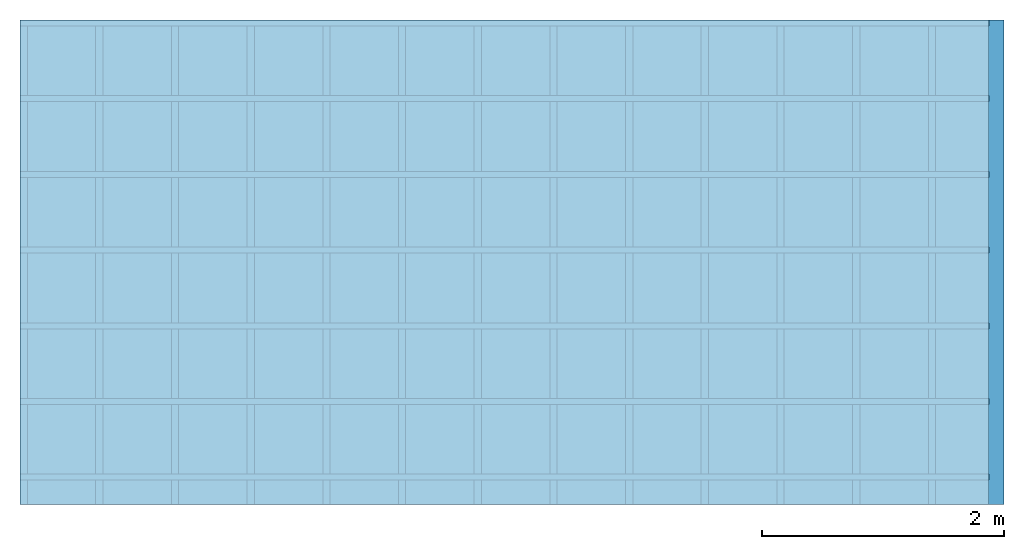
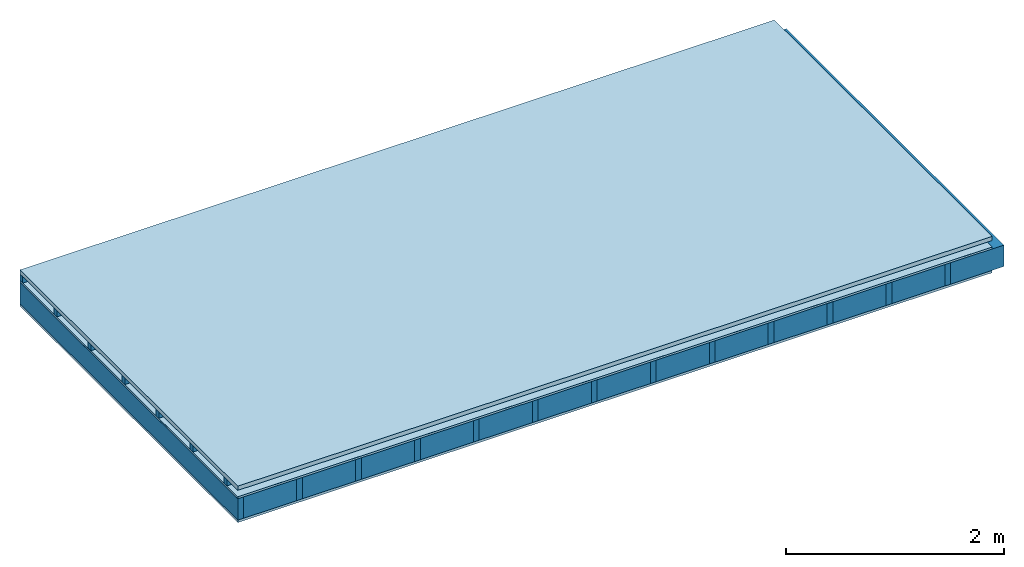
# One storey: 4 plates, 3 members, 1 element without a shape of its own.
"""IFC4 building model written with IfcOpenShell, lengths in metres."""

from ifc_helpers import new_model, si_unit, derived_unit, direction, frame, frame_2d, origin, origin_with_axes, place, context, project, spatial, rectangle, extrude, material, layer, layer_set, type_object, element, aggregate, save


model = new_model("IFC4")

# Units and contexts
plan_context = context("Plan", 3, precision=1e-05, world=origin(), true_north=direction((0.0, 1.0)))
model_context = context("Model", 3, precision=1e-05, world=origin(), true_north=direction((0.0, 1.0)))
ifc_project = project(units=[si_unit("LENGTHUNIT", "METRE"), derived_unit("SOUNDPRESSUREUNIT", [(si_unit("PRESSUREUNIT", "PASCAL", prefix="MICRO"), 0)]), si_unit("ENERGYUNIT", "JOULE", prefix="MEGA"), si_unit("MASSUNIT", "GRAM", prefix="KILO"), derived_unit("THERMALTRANSMITTANCEUNIT", [(si_unit("POWERUNIT", "WATT"), 1), (si_unit("AREAUNIT", "SQUARE_METRE"), -1), (si_unit("THERMODYNAMICTEMPERATUREUNIT", "KELVIN"), -1)]), derived_unit("AREADENSITYUNIT", [(si_unit("MASSUNIT", "GRAM", prefix="KILO"), 1), (si_unit("AREAUNIT", "SQUARE_METRE"), -1)]), derived_unit("USERDEFINED", [(si_unit("ENERGYUNIT", "JOULE", prefix="MEGA"), 1), (si_unit("AREAUNIT", "SQUARE_METRE"), -1)])], contexts=[plan_context, model_context])

# Site, building, storey
site = spatial("IfcSite", under=ifc_project)
building_placement = place(None, origin())
building = spatial("IfcBuilding", under=site, at=building_placement)
storey_placement = place(building_placement, origin())
storey = spatial("IfcBuildingStorey", under=building, at=storey_placement)

# Slab, members, plates
ifc_material_1 = material(Name="Roof tiles", Category="03.015")
ifc_layer_1 = layer(ifc_material_1, 0.047, Name="Roofing")
ifc_layer_2 = layer(None, 0.072, Name="Battens / profiles")
ifc_material_2 = material(Name="Roofing underlay", Category="09.008")
ifc_layer_3 = layer(ifc_material_2, 0.00018, Name="Under the roof")
ifc_material_3 = material(Category="10.009")
ifc_layer_4 = layer(ifc_material_3, 0.022, Name="Exterior insulation layer 1")
ifc_material_4 = material(Name="no composite action")
ifc_layer_5 = layer(ifc_material_4, 0.0, Name="Bond")
ifc_layer_6 = layer(None, 0.24, Name="Supporting structure")
ifc_material_5 = material(Name="of the art")
ifc_layer_7 = layer(ifc_material_5, 0.0, Name="Bond")
ifc_material_6 = material(Category="07.001")
ifc_layer_8 = layer(ifc_material_6, 0.027, Name="Lower layer 1")
ifc_layer_set = layer_set([ifc_layer_1, ifc_layer_2, ifc_layer_3, ifc_layer_4, ifc_layer_5, ifc_layer_6, ifc_layer_7, ifc_layer_8])
slab_type = type_object("IfcSlabType", Name="E0066", PredefinedType="NOTDEFINED", material=ifc_layer_set)
slab_placement = place(None, frame((0.0, 0.0, 0.0), z_axis=(0.0, 0.0, -1.0), x_axis=(1.0, 0.0, 0.0)))
slab = element("IfcSlab", 1, at=slab_placement, inside=storey, type_object=slab_type, material=ifc_layer_set, Name="Slab #1")
ifc_material_7 = material()
member_1_placement = place(slab_placement, origin())
member_1 = element("IfcMember", 2, at=member_1_placement, material=ifc_material_7, Name="Battens / profiles", context=plan_context, shape_type="SweptSolid", body=[
    extrude(rectangle(XDim=0.05, YDim=0.072, at=frame_2d((0.025, 0.036), x_axis=(1.0, 0.0))), frame((0.0, 0.0, 0.047), z_axis=(1.0, 0.0, 0.0), x_axis=(0.0, 1.0, 0.0)), (0.0, 0.0, 1.0), 8.0),
    extrude(rectangle(XDim=0.05, YDim=0.072, at=frame_2d((0.025, 0.036), x_axis=(1.0, 0.0))), frame((0.0, 0.625, 0.047), z_axis=(1.0, 0.0, 0.0), x_axis=(0.0, 1.0, 0.0)), (0.0, 0.0, 1.0), 8.0),
    extrude(rectangle(XDim=0.05, YDim=0.072, at=frame_2d((0.025, 0.036), x_axis=(1.0, 0.0))), frame((0.0, 1.25, 0.047), z_axis=(1.0, 0.0, 0.0), x_axis=(0.0, 1.0, 0.0)), (0.0, 0.0, 1.0), 8.0),
    extrude(rectangle(XDim=0.05, YDim=0.072, at=frame_2d((0.025, 0.036), x_axis=(1.0, 0.0))), frame((0.0, 1.875, 0.047), z_axis=(1.0, 0.0, 0.0), x_axis=(0.0, 1.0, 0.0)), (0.0, 0.0, 1.0), 8.0),
    extrude(rectangle(XDim=0.05, YDim=0.072, at=frame_2d((0.025, 0.036), x_axis=(1.0, 0.0))), frame((0.0, 2.5, 0.047), z_axis=(1.0, 0.0, 0.0), x_axis=(0.0, 1.0, 0.0)), (0.0, 0.0, 1.0), 8.0),
    extrude(rectangle(XDim=0.05, YDim=0.072, at=frame_2d((0.025, 0.036), x_axis=(1.0, 0.0))), frame((0.0, 3.125, 0.047), z_axis=(1.0, 0.0, 0.0), x_axis=(0.0, 1.0, 0.0)), (0.0, 0.0, 1.0), 8.0),
    extrude(rectangle(XDim=0.05, YDim=0.072, at=frame_2d((0.025, 0.036), x_axis=(1.0, 0.0))), frame((0.0, 3.75, 0.047), z_axis=(1.0, 0.0, 0.0), x_axis=(0.0, 1.0, 0.0)), (0.0, 0.0, 1.0), 8.0),
])
ifc_material_8 = material()
member_2_placement = place(slab_placement, origin())
member_2 = element("IfcMember", 3, at=member_2_placement, material=ifc_material_8, Name="Supporting structure", context=plan_context, shape_type="SweptSolid", body=[
    extrude(rectangle(XDim=0.06, YDim=0.24, at=frame_2d((0.03, 0.12), x_axis=(1.0, 0.0))), frame((0.0, 4.0, 0.14118), z_axis=(0.0, -1.0, 0.0), x_axis=(1.0, 0.0, 0.0)), (0.0, 0.0, 1.0), 4.0),
    extrude(rectangle(XDim=0.06, YDim=0.24, at=frame_2d((0.03, 0.12), x_axis=(1.0, 0.0))), frame((0.625, 4.0, 0.14118), z_axis=(0.0, -1.0, 0.0), x_axis=(1.0, 0.0, 0.0)), (0.0, 0.0, 1.0), 4.0),
    extrude(rectangle(XDim=0.06, YDim=0.24, at=frame_2d((0.03, 0.12), x_axis=(1.0, 0.0))), frame((1.25, 4.0, 0.14118), z_axis=(0.0, -1.0, 0.0), x_axis=(1.0, 0.0, 0.0)), (0.0, 0.0, 1.0), 4.0),
    extrude(rectangle(XDim=0.06, YDim=0.24, at=frame_2d((0.03, 0.12), x_axis=(1.0, 0.0))), frame((1.875, 4.0, 0.14118), z_axis=(0.0, -1.0, 0.0), x_axis=(1.0, 0.0, 0.0)), (0.0, 0.0, 1.0), 4.0),
    extrude(rectangle(XDim=0.06, YDim=0.24, at=frame_2d((0.03, 0.12), x_axis=(1.0, 0.0))), frame((2.5, 4.0, 0.14118), z_axis=(0.0, -1.0, 0.0), x_axis=(1.0, 0.0, 0.0)), (0.0, 0.0, 1.0), 4.0),
    extrude(rectangle(XDim=0.06, YDim=0.24, at=frame_2d((0.03, 0.12), x_axis=(1.0, 0.0))), frame((3.125, 4.0, 0.14118), z_axis=(0.0, -1.0, 0.0), x_axis=(1.0, 0.0, 0.0)), (0.0, 0.0, 1.0), 4.0),
    extrude(rectangle(XDim=0.06, YDim=0.24, at=frame_2d((0.03, 0.12), x_axis=(1.0, 0.0))), frame((3.75, 4.0, 0.14118), z_axis=(0.0, -1.0, 0.0), x_axis=(1.0, 0.0, 0.0)), (0.0, 0.0, 1.0), 4.0),
    extrude(rectangle(XDim=0.06, YDim=0.24, at=frame_2d((0.03, 0.12), x_axis=(1.0, 0.0))), frame((4.375, 4.0, 0.14118), z_axis=(0.0, -1.0, 0.0), x_axis=(1.0, 0.0, 0.0)), (0.0, 0.0, 1.0), 4.0),
    extrude(rectangle(XDim=0.06, YDim=0.24, at=frame_2d((0.03, 0.12), x_axis=(1.0, 0.0))), frame((5.0, 4.0, 0.14118), z_axis=(0.0, -1.0, 0.0), x_axis=(1.0, 0.0, 0.0)), (0.0, 0.0, 1.0), 4.0),
    extrude(rectangle(XDim=0.06, YDim=0.24, at=frame_2d((0.03, 0.12), x_axis=(1.0, 0.0))), frame((5.625, 4.0, 0.14118), z_axis=(0.0, -1.0, 0.0), x_axis=(1.0, 0.0, 0.0)), (0.0, 0.0, 1.0), 4.0),
    extrude(rectangle(XDim=0.06, YDim=0.24, at=frame_2d((0.03, 0.12), x_axis=(1.0, 0.0))), frame((6.25, 4.0, 0.14118), z_axis=(0.0, -1.0, 0.0), x_axis=(1.0, 0.0, 0.0)), (0.0, 0.0, 1.0), 4.0),
    extrude(rectangle(XDim=0.06, YDim=0.24, at=frame_2d((0.03, 0.12), x_axis=(1.0, 0.0))), frame((6.875, 4.0, 0.14118), z_axis=(0.0, -1.0, 0.0), x_axis=(1.0, 0.0, 0.0)), (0.0, 0.0, 1.0), 4.0),
    extrude(rectangle(XDim=0.06, YDim=0.24, at=frame_2d((0.03, 0.12), x_axis=(1.0, 0.0))), frame((7.5, 4.0, 0.14118), z_axis=(0.0, -1.0, 0.0), x_axis=(1.0, 0.0, 0.0)), (0.0, 0.0, 1.0), 4.0),
])
ifc_material_9 = material()
member_3_placement = place(slab_placement, origin())
member_3 = element("IfcMember", 4, at=member_3_placement, material=ifc_material_9, Name="Cavity", context=plan_context, shape_type="SweptSolid", body=[
    extrude(rectangle(XDim=0.565, YDim=0.24, at=frame_2d((0.2825, 0.12), x_axis=(1.0, 0.0))), frame((0.06, 4.0, 0.14118), z_axis=(0.0, -1.0, 0.0), x_axis=(1.0, 0.0, 0.0)), (0.0, 0.0, 1.0), 4.0),
    extrude(rectangle(XDim=0.565, YDim=0.24, at=frame_2d((0.2825, 0.12), x_axis=(1.0, 0.0))), frame((0.685, 4.0, 0.14118), z_axis=(0.0, -1.0, 0.0), x_axis=(1.0, 0.0, 0.0)), (0.0, 0.0, 1.0), 4.0),
    extrude(rectangle(XDim=0.565, YDim=0.24, at=frame_2d((0.2825, 0.12), x_axis=(1.0, 0.0))), frame((1.31, 4.0, 0.14118), z_axis=(0.0, -1.0, 0.0), x_axis=(1.0, 0.0, 0.0)), (0.0, 0.0, 1.0), 4.0),
    extrude(rectangle(XDim=0.565, YDim=0.24, at=frame_2d((0.2825, 0.12), x_axis=(1.0, 0.0))), frame((1.935, 4.0, 0.14118), z_axis=(0.0, -1.0, 0.0), x_axis=(1.0, 0.0, 0.0)), (0.0, 0.0, 1.0), 4.0),
    extrude(rectangle(XDim=0.565, YDim=0.24, at=frame_2d((0.2825, 0.12), x_axis=(1.0, 0.0))), frame((2.56, 4.0, 0.14118), z_axis=(0.0, -1.0, 0.0), x_axis=(1.0, 0.0, 0.0)), (0.0, 0.0, 1.0), 4.0),
    extrude(rectangle(XDim=0.565, YDim=0.24, at=frame_2d((0.2825, 0.12), x_axis=(1.0, 0.0))), frame((3.185, 4.0, 0.14118), z_axis=(0.0, -1.0, 0.0), x_axis=(1.0, 0.0, 0.0)), (0.0, 0.0, 1.0), 4.0),
    extrude(rectangle(XDim=0.565, YDim=0.24, at=frame_2d((0.2825, 0.12), x_axis=(1.0, 0.0))), frame((3.81, 4.0, 0.14118), z_axis=(0.0, -1.0, 0.0), x_axis=(1.0, 0.0, 0.0)), (0.0, 0.0, 1.0), 4.0),
    extrude(rectangle(XDim=0.565, YDim=0.24, at=frame_2d((0.2825, 0.12), x_axis=(1.0, 0.0))), frame((4.435, 4.0, 0.14118), z_axis=(0.0, -1.0, 0.0), x_axis=(1.0, 0.0, 0.0)), (0.0, 0.0, 1.0), 4.0),
    extrude(rectangle(XDim=0.565, YDim=0.24, at=frame_2d((0.2825, 0.12), x_axis=(1.0, 0.0))), frame((5.06, 4.0, 0.14118), z_axis=(0.0, -1.0, 0.0), x_axis=(1.0, 0.0, 0.0)), (0.0, 0.0, 1.0), 4.0),
    extrude(rectangle(XDim=0.565, YDim=0.24, at=frame_2d((0.2825, 0.12), x_axis=(1.0, 0.0))), frame((5.685, 4.0, 0.14118), z_axis=(0.0, -1.0, 0.0), x_axis=(1.0, 0.0, 0.0)), (0.0, 0.0, 1.0), 4.0),
    extrude(rectangle(XDim=0.565, YDim=0.24, at=frame_2d((0.2825, 0.12), x_axis=(1.0, 0.0))), frame((6.31, 4.0, 0.14118), z_axis=(0.0, -1.0, 0.0), x_axis=(1.0, 0.0, 0.0)), (0.0, 0.0, 1.0), 4.0),
    extrude(rectangle(XDim=0.565, YDim=0.24, at=frame_2d((0.2825, 0.12), x_axis=(1.0, 0.0))), frame((6.935, 4.0, 0.14118), z_axis=(0.0, -1.0, 0.0), x_axis=(1.0, 0.0, 0.0)), (0.0, 0.0, 1.0), 4.0),
    extrude(rectangle(XDim=0.565, YDim=0.24, at=frame_2d((0.2825, 0.12), x_axis=(1.0, 0.0))), frame((7.56, 4.0, 0.14118), z_axis=(0.0, -1.0, 0.0), x_axis=(1.0, 0.0, 0.0)), (0.0, 0.0, 1.0), 4.0),
])
plate_1_placement = place(slab_placement, origin())
plate_1 = element("IfcPlate", 5, at=plate_1_placement, material=ifc_material_1, Name="Roofing", context=plan_context, shape_type="SweptSolid", body=[
    extrude(rectangle(XDim=8.0, YDim=4.0, at=frame_2d((4.0, 2.0), x_axis=(1.0, 0.0))), origin_with_axes(), (0.0, 0.0, 1.0), 0.047),
])
plate_2_placement = place(slab_placement, origin())
plate_2 = element("IfcPlate", 6, at=plate_2_placement, material=ifc_material_2, Name="Under the roof", context=plan_context, shape_type="SweptSolid", body=[
    extrude(rectangle(XDim=8.0, YDim=4.0, at=frame_2d((4.0, 2.0), x_axis=(1.0, 0.0))), frame((0.0, 0.0, 0.119), z_axis=(0.0, 0.0, 1.0), x_axis=(1.0, 0.0, 0.0)), (0.0, 0.0, 1.0), 0.00018),
])
plate_3_placement = place(slab_placement, origin())
plate_3 = element("IfcPlate", 7, at=plate_3_placement, material=ifc_material_3, Name="Exterior insulation layer 1", context=plan_context, shape_type="SweptSolid", body=[
    extrude(rectangle(XDim=8.0, YDim=4.0, at=frame_2d((4.0, 2.0), x_axis=(1.0, 0.0))), frame((0.0, 0.0, 0.11918), z_axis=(0.0, 0.0, 1.0), x_axis=(1.0, 0.0, 0.0)), (0.0, 0.0, 1.0), 0.022),
])
plate_4_placement = place(slab_placement, origin())
plate_4 = element("IfcPlate", 8, at=plate_4_placement, material=ifc_material_6, Name="Lower layer 1", context=plan_context, shape_type="SweptSolid", body=[
    extrude(rectangle(XDim=8.0, YDim=4.0, at=frame_2d((4.0, 2.0), x_axis=(1.0, 0.0))), frame((0.0, 0.0, 0.38118), z_axis=(0.0, 0.0, 1.0), x_axis=(1.0, 0.0, 0.0)), (0.0, 0.0, 1.0), 0.027),
])
aggregate(slab, [plate_1, member_1, plate_2, plate_3, member_2, member_3, plate_4])

save(model, "model.ifc")
